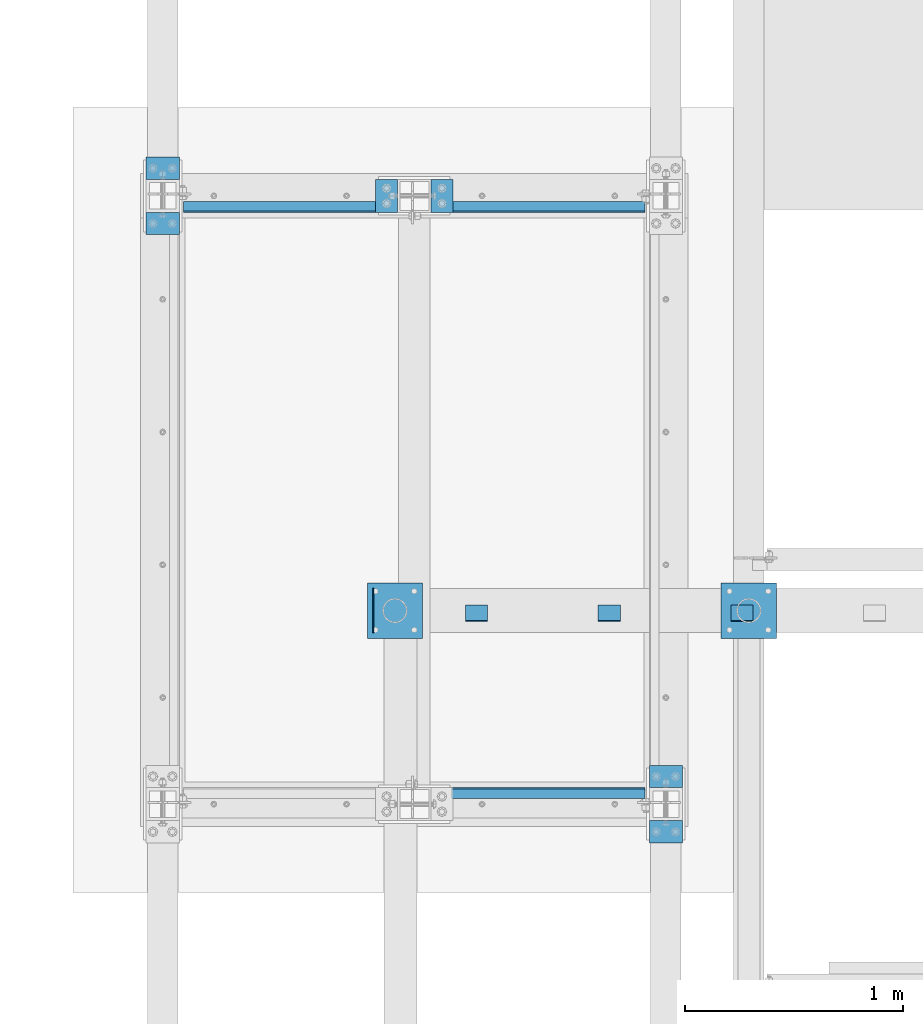
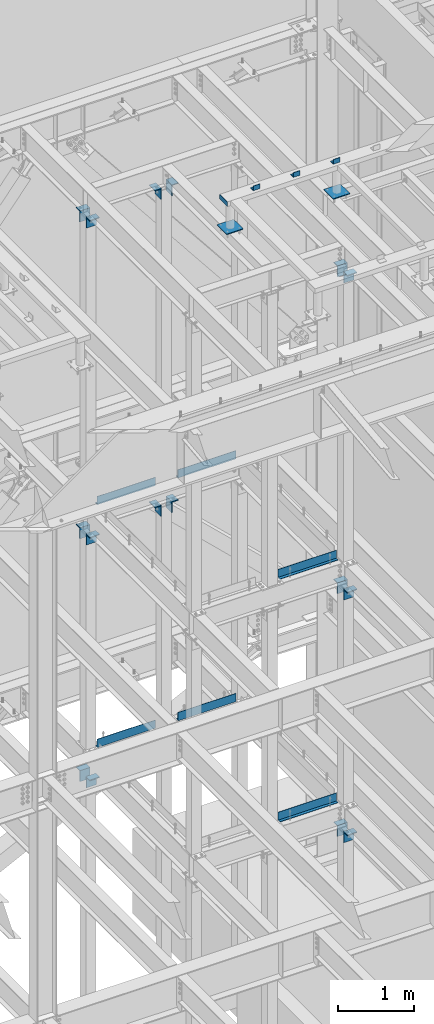
# One storey, part 892 of 1179: 28 beams, 13 elements without a shape of their own.
"""IFC2X3 building model written with IfcOpenShell, lengths in millimetres."""

from ifc_helpers import new_model, si_unit, frame, origin_with_axes, place, context, subcontext, project, spatial, faceted_brep, material, type_object, element, aggregate, save


model = new_model("IFC2X3")

# Units and contexts
model_context = context("Model", 3, precision=1e-05, world=origin_with_axes())
body_context = subcontext(model_context, "Body", "Model", "MODEL_VIEW")
ifc_project = project(units=[si_unit("LENGTHUNIT", "METRE", prefix="MILLI"), si_unit("AREAUNIT", "SQUARE_METRE"), si_unit("VOLUMEUNIT", "CUBIC_METRE"), si_unit("MASSUNIT", "GRAM", prefix="KILO"), si_unit("TIMEUNIT", "SECOND"), si_unit("PLANEANGLEUNIT", "RADIAN"), si_unit("SOLIDANGLEUNIT", "STERADIAN"), si_unit("THERMODYNAMICTEMPERATUREUNIT", "DEGREE_CELSIUS"), si_unit("LUMINOUSINTENSITYUNIT", "LUMEN")], contexts=[model_context])

# Site, building, storey
site_placement = place(None, origin_with_axes())
site = spatial("IfcSite", under=ifc_project, at=site_placement, CompositionType="ELEMENT")
building_placement = place(site_placement, origin_with_axes())
building = spatial("IfcBuilding", under=site, at=building_placement, Name="Undefined", CompositionType="ELEMENT")
storey_placement = place(building_placement, origin_with_axes())
storey = spatial("IfcBuildingStorey", under=building, at=storey_placement, Name="Undefined", CompositionType="ELEMENT", Elevation=0.0)

# Assembly, beams
assembly_1_placement = place(storey_placement, origin_with_axes())
assembly_1 = element("IfcElementAssembly", 1, at=assembly_1_placement, inside=storey, Name="FRAME", AssemblyPlace="NOTDEFINED", PredefinedType="RIGID_FRAME")
ifc_material = material(Name="STEEL/A36")
beam_type_1 = type_object("IfcBeamType", Name="L3X3X1/4", PredefinedType="NOTDEFINED")
beam_1_placement = place(assembly_1_placement, frame((14484.35, 37515.8, 13798.55), z_axis=(0.0, 1.0, 0.0), x_axis=(1.0, 0.0, 0.0)))
beam_1 = element("IfcBeam", 2, at=beam_1_placement, type_object=beam_type_1, material=ifc_material, Name="ANGLE", ObjectType="L3X3X1/4", context=body_context, shape_type="Brep", body=[
    faceted_brep([(0.0, 38.0999999999985, -38.0999999999999), (0.0, 38.0999999999985, 38.0999999999999), (101.600000000035, 38.0999999999985, 38.099999999994), (101.599999999962, 38.0999999999985, -38.1000000000058), (0.0, 31.75, 38.1000000000004), (101.600000000035, 31.75, 38.099999999994), (0.0, 31.75, -31.75), (101.599999999969, 31.75, -31.7500000000064), (0.0, -38.0999999999985, -31.75), (101.599999999969, -38.0999999999985, -31.7500000000064), (0.0, -38.0999999999985, -38.0999999999999), (101.599999999962, -38.0999999999985, -38.1000000000058)], [[[0, 1, 2, 3]], [[1, 4, 5, 2]], [[4, 6, 7, 5]], [[6, 8, 9, 7]], [[8, 10, 11, 9]], [[10, 0, 3, 11]], [[5, 7, 9, 11, 3, 2]], [[10, 8, 6, 4, 1, 0]]]),
])
beam_2_placement = place(assembly_1_placement, frame((13874.75, 37515.8, 13798.55), z_axis=(0.0, 1.0, 0.0), x_axis=(1.0, 0.0, 0.0)))
beam_2 = element("IfcBeam", 3, at=beam_2_placement, type_object=beam_type_1, material=ifc_material, Name="ANGLE", ObjectType="L3X3X1/4", context=body_context, shape_type="Brep", body=[
    faceted_brep([(0.0, 38.0999999999985, -38.0999999999999), (0.0, 38.0999999999985, 38.0999999999999), (101.600000000035, 38.0999999999985, 38.099999999994), (101.599999999962, 38.0999999999985, -38.1000000000058), (0.0, 31.75, 38.1000000000004), (101.600000000035, 31.75, 38.099999999994), (0.0, 31.75, -31.75), (101.599999999969, 31.75, -31.7500000000064), (0.0, -38.0999999999985, -31.75), (101.599999999969, -38.0999999999985, -31.7500000000064), (0.0, -38.0999999999985, -38.0999999999999), (101.599999999962, -38.0999999999985, -38.1000000000058)], [[[0, 1, 2, 3]], [[1, 4, 5, 2]], [[4, 6, 7, 5]], [[6, 8, 9, 7]], [[8, 10, 11, 9]], [[10, 0, 3, 11]], [[5, 7, 9, 11, 3, 2]], [[10, 8, 6, 4, 1, 0]]]),
])
beam_3_placement = place(assembly_1_placement, frame((13265.15, 37515.8, 13798.55), z_axis=(0.0, 1.0, 0.0), x_axis=(1.0, 0.0, 0.0)))
beam_3 = element("IfcBeam", 4, at=beam_3_placement, type_object=beam_type_1, material=ifc_material, Name="ANGLE", ObjectType="L3X3X1/4", context=body_context, shape_type="Brep", body=[
    faceted_brep([(0.0, 38.0999999999985, -38.0999999999999), (0.0, 38.0999999999985, 38.0999999999999), (101.600000000035, 38.0999999999985, 38.099999999994), (101.599999999962, 38.0999999999985, -38.1000000000058), (0.0, 31.75, 38.1000000000004), (101.600000000035, 31.75, 38.099999999994), (0.0, 31.75, -31.75), (101.599999999969, 31.75, -31.7500000000064), (0.0, -38.0999999999985, -31.75), (101.599999999969, -38.0999999999985, -31.7500000000064), (0.0, -38.0999999999985, -38.0999999999999), (101.599999999962, -38.0999999999985, -38.1000000000058)], [[[0, 1, 2, 3]], [[1, 4, 5, 2]], [[4, 6, 7, 5]], [[6, 8, 9, 7]], [[8, 10, 11, 9]], [[10, 0, 3, 11]], [[5, 7, 9, 11, 3, 2]], [[10, 8, 6, 4, 1, 0]]]),
])
beam_type_2 = type_object("IfcBeamType", PredefinedType="NOTDEFINED")
beam_4_placement = place(assembly_1_placement, frame((12842.081, 37630.1, 13722.35), z_axis=(0.0, 0.0, -1.0), x_axis=(0.0, -1.0, 0.0)))
beam_4 = element("IfcBeam", 5, at=beam_4_placement, type_object=beam_type_2, material=ifc_material, Name="PLATE", context=body_context, shape_type="Brep", body=[
    faceted_brep([(0.0, 2.38149999999951, -38.0999999999985), (0.0, 2.38149999999951, 38.0999999999985), (203.199999999997, 2.38150000000314, 38.1000000000004), (203.199999999997, 2.38150000000314, -38.1000000000004), (0.0, -2.38149999999951, 38.0999999999985), (203.199999999997, -2.38150000000314, 38.1000000000004), (0.0, -2.38149999999951, -38.0999999999985), (203.199999999997, -2.38150000000314, -38.1000000000004)], [[[0, 1, 2, 3]], [[1, 4, 5, 2]], [[4, 6, 7, 5]], [[6, 0, 3, 7]], [[5, 7, 3, 2]], [[6, 4, 1, 0]]]),
])

# Assembly, beam
assembly_2_placement = place(storey_placement, origin_with_axes())
assembly_2 = element("IfcElementAssembly", 6, at=assembly_2_placement, inside=storey, Name="BEAM", AssemblyPlace="NOTDEFINED", PredefinedType="RIGID_FRAME")
beam_type_3 = type_object("IfcBeamType", PredefinedType="NOTDEFINED")
beam_5_placement = place(assembly_2_placement, frame((13646.1498786982, 36712.5249652951, 8147.05000610352), z_axis=(1.0, 0.0, 0.0), x_axis=(0.0, 0.0, -1.0)))
beam_5 = element("IfcBeam", 7, at=beam_5_placement, type_object=beam_type_3, material=ifc_material, Name="BENT_PLATE", context=body_context, shape_type="Brep", body=[
    faceted_brep([(0.0, -3.17500000000291, -444.5), (0.0, -3.17500000000291, 444.5), (0.0, 3.17500000000291, 444.5), (0.0, 3.17500000000291, -444.5), (133.350006103513, 3.17500000000291, 444.5), (133.350006103513, 3.17500000000291, -444.5), (127.000006103513, -3.17500000000291, -444.5), (127.000006103513, -3.17500000000291, 444.5), (133.350006103513, -47.6249984741225, 444.5), (133.350006103513, -47.6249984741225, -444.5), (127.000006103513, -47.6249984741225, 444.5), (127.000006103513, -47.6249984741225, -444.5)], [[[0, 1, 2, 3]], [[3, 2, 4, 5]], [[1, 0, 6, 7]], [[5, 4, 8, 9]], [[4, 2, 1, 7, 10, 8]], [[7, 6, 11, 10]], [[6, 0, 3, 5, 9, 11]], [[10, 11, 9, 8]]]),
])
aggregate(assembly_2, [beam_5])

# Assembly, beams
assembly_3_placement = place(storey_placement, origin_with_axes())
assembly_3 = element("IfcElementAssembly", 8, at=assembly_3_placement, inside=storey, Name="BEAM", AssemblyPlace="NOTDEFINED", PredefinedType="RIGID_FRAME")
beam_6_placement = place(assembly_3_placement, frame((13646.15, 39360.4749984741, 8147.05000610352), z_axis=(1.0, 0.0, 0.0), x_axis=(0.0, 0.0, -1.0)))
beam_6 = element("IfcBeam", 9, at=beam_6_placement, type_object=beam_type_3, material=ifc_material, Name="BENT_PLATE", context=body_context, shape_type="Brep", body=[
    faceted_brep([(0.0, -3.17500000000291, -444.5), (0.0, -3.17500000000291, 444.5), (0.0, 3.17500000000291, 444.5), (0.0, 3.17500000000291, -444.5), (127.000006103513, 3.17500000000291, 444.5), (127.000006103513, 3.17500000000291, -444.5), (133.350006103513, -3.17500000000291, -444.5), (133.350006103513, -3.17500000000291, 444.5), (127.000006103513, 47.6250015258702, 444.5), (127.000006103513, 47.6250015258702, -444.5), (133.350006103513, 47.6250015258702, 444.5), (133.350006103513, 47.6250015258702, -444.5)], [[[0, 1, 2, 3]], [[3, 2, 4, 5]], [[1, 0, 6, 7]], [[5, 4, 8, 9]], [[4, 2, 1, 7, 10, 8]], [[7, 6, 11, 10]], [[6, 0, 3, 5, 9, 11]], [[10, 11, 9, 8]]]),
])
beam_7_placement = place(assembly_3_placement, frame((12414.2500030518, 39360.4749984741, 8147.05000610352), z_axis=(1.0, 0.0, 0.0), x_axis=(0.0, 0.0, -1.0)))
beam_7 = element("IfcBeam", 10, at=beam_7_placement, type_object=beam_type_3, material=ifc_material, Name="BENT_PLATE", context=body_context, shape_type="Brep", body=[
    faceted_brep([(0.0, -3.17500000000291, -444.5), (0.0, -3.17500000000291, 444.5), (0.0, 3.17500000000291, 444.5), (0.0, 3.17500000000291, -444.5), (127.000006103513, 3.17500000000291, 444.5), (127.000006103513, 3.17500000000291, -444.5), (133.350006103513, -3.17500000000291, -444.5), (133.350006103513, -3.17500000000291, 444.5), (127.000006103513, 47.6250015258702, 444.5), (127.000006103513, 47.6250015258702, -444.5), (133.350006103513, 47.6250015258702, 444.5), (133.350006103513, 47.6250015258702, -444.5)], [[[0, 1, 2, 3]], [[3, 2, 4, 5]], [[1, 0, 6, 7]], [[5, 4, 8, 9]], [[4, 2, 1, 7, 10, 8]], [[7, 6, 11, 10]], [[6, 0, 3, 5, 9, 11]], [[10, 11, 9, 8]]]),
])
aggregate(assembly_3, [beam_6, beam_7])

# Assembly, beam
assembly_4_placement = place(storey_placement, origin_with_axes())
assembly_4 = element("IfcElementAssembly", 11, at=assembly_4_placement, inside=storey, Name="BEAM", AssemblyPlace="NOTDEFINED", PredefinedType="RIGID_FRAME")
beam_8_placement = place(assembly_4_placement, frame((13646.15, 36712.5249984741, 4235.45000610352), z_axis=(1.0, 0.0, 0.0), x_axis=(0.0, 0.0, -1.0)))
beam_8 = element("IfcBeam", 12, at=beam_8_placement, type_object=beam_type_3, material=ifc_material, Name="BENT_PLATE", context=body_context, shape_type="Brep", body=[
    faceted_brep([(0.0, -3.17500000000291, -444.5), (0.0, -3.17500000000291, 444.5), (0.0, 3.17500000000291, 444.5), (0.0, 3.17500000000291, -444.5), (133.350006103513, 3.17500000000291, 444.5), (133.350006103513, 3.17500000000291, -444.5), (127.000006103513, -3.17500000000291, -444.5), (127.000006103513, -3.17500000000291, 444.5), (133.350006103513, -47.6249984741225, 444.5), (133.350006103513, -47.6249984741225, -444.5), (127.000006103513, -47.6249984741225, 444.5), (127.000006103513, -47.6249984741225, -444.5)], [[[0, 1, 2, 3]], [[3, 2, 4, 5]], [[1, 0, 6, 7]], [[5, 4, 8, 9]], [[4, 2, 1, 7, 10, 8]], [[7, 6, 11, 10]], [[6, 0, 3, 5, 9, 11]], [[10, 11, 9, 8]]]),
])
aggregate(assembly_4, [beam_8])

# Assembly, beams
assembly_5_placement = place(storey_placement, origin_with_axes())
assembly_5 = element("IfcElementAssembly", 13, at=assembly_5_placement, inside=storey, Name="BEAM", AssemblyPlace="NOTDEFINED", PredefinedType="RIGID_FRAME")
beam_9_placement = place(assembly_5_placement, frame((13646.15, 39360.4749984741, 4235.45000610352), z_axis=(1.0, 0.0, 0.0), x_axis=(0.0, 0.0, -1.0)))
beam_9 = element("IfcBeam", 14, at=beam_9_placement, type_object=beam_type_3, material=ifc_material, Name="BENT_PLATE", context=body_context, shape_type="Brep", body=[
    faceted_brep([(0.0, -3.17500000000291, -444.5), (0.0, -3.17500000000291, 444.5), (0.0, 3.17500000000291, 444.5), (0.0, 3.17500000000291, -444.5), (127.000006103513, 3.17500000000291, 444.5), (127.000006103513, 3.17500000000291, -444.5), (133.350006103513, -3.17500000000291, -444.5), (133.350006103513, -3.17500000000291, 444.5), (127.000006103513, 47.6250015258702, 444.5), (127.000006103513, 47.6250015258702, -444.5), (133.350006103513, 47.6250015258702, 444.5), (133.350006103513, 47.6250015258702, -444.5)], [[[0, 1, 2, 3]], [[3, 2, 4, 5]], [[1, 0, 6, 7]], [[5, 4, 8, 9]], [[4, 2, 1, 7, 10, 8]], [[7, 6, 11, 10]], [[6, 0, 3, 5, 9, 11]], [[10, 11, 9, 8]]]),
])
beam_10_placement = place(assembly_5_placement, frame((12414.2500030518, 39360.4749984741, 4235.45000610352), z_axis=(1.0, 0.0, 0.0), x_axis=(0.0, 0.0, -1.0)))
beam_10 = element("IfcBeam", 15, at=beam_10_placement, type_object=beam_type_3, material=ifc_material, Name="BENT_PLATE", context=body_context, shape_type="Brep", body=[
    faceted_brep([(0.0, -3.17500000000291, -444.5), (0.0, -3.17500000000291, 444.5), (0.0, 3.17500000000291, 444.5), (0.0, 3.17500000000291, -444.5), (127.000006103513, 3.17500000000291, 444.5), (127.000006103513, 3.17500000000291, -444.5), (133.350006103513, -3.17500000000291, -444.5), (133.350006103513, -3.17500000000291, 444.5), (127.000006103513, 47.6250015258702, 444.5), (127.000006103513, 47.6250015258702, -444.5), (133.350006103513, 47.6250015258702, 444.5), (133.350006103513, 47.6250015258702, -444.5)], [[[0, 1, 2, 3]], [[3, 2, 4, 5]], [[1, 0, 6, 7]], [[5, 4, 8, 9]], [[4, 2, 1, 7, 10, 8]], [[7, 6, 11, 10]], [[6, 0, 3, 5, 9, 11]], [[10, 11, 9, 8]]]),
])
aggregate(assembly_5, [beam_9, beam_10])

assembly_6_placement = place(storey_placement, origin_with_axes())
assembly_6 = element("IfcElementAssembly", 16, at=assembly_6_placement, inside=storey, Name="COLUMN", AssemblyPlace="NOTDEFINED", PredefinedType="RIGID_FRAME")
beam_type_4 = type_object("IfcBeamType", PredefinedType="NOTDEFINED")
beam_11_placement = place(assembly_6_placement, frame((12852.4000014634, 39433.5000000217, 12763.5), z_axis=(0.0, 1.0, 0.0), x_axis=(1.0, 0.0, 0.0)))
beam_11 = element("IfcBeam", 17, at=beam_11_placement, type_object=beam_type_4, material=ifc_material, Name="BENT_PLATE", context=body_context, shape_type="Brep", body=[
    faceted_brep([(7.27595761418343e-12, -6.35000000000036, -76.1999999999971), (0.0, -6.35000000000036, 76.2000000000044), (0.0, 6.35000000000036, 76.2000000000044), (-7.27595761418343e-12, 6.35000000000036, -76.1999999999971), (88.8999984741222, 6.34999999999991, 76.2000000000007), (88.8999984741222, 6.34999999999991, -76.2000000000007), (101.599998474123, -6.34999999999991, -76.2000000000007), (101.599998474123, -6.34999999999991, 76.2000000000007), (88.8999984741222, 171.450003051757, 76.2000000000007), (88.8999984741222, 171.450003051757, -76.2000000000007), (101.599998474123, 171.450003051757, 76.2000000000007), (101.599998474123, 171.450003051757, -76.2000000000007)], [[[0, 1, 2, 3]], [[3, 2, 4, 5]], [[1, 0, 6, 7]], [[5, 4, 8, 9]], [[4, 2, 1, 7, 10, 8]], [[7, 6, 11, 10]], [[6, 0, 3, 5, 9, 11]], [[10, 11, 9, 8]]]),
])
beam_12_placement = place(assembly_6_placement, frame((13207.9999984116, 39433.500000021, 12763.5), z_axis=(0.0, 1.0, 0.0), x_axis=(-1.0, 0.0, 0.0)))
beam_12 = element("IfcBeam", 18, at=beam_12_placement, type_object=beam_type_4, material=ifc_material, Name="BENT_PLATE", context=body_context, shape_type="Brep", body=[
    faceted_brep([(7.27595761418343e-12, -6.35000000000036, -76.1999999999971), (0.0, -6.35000000000036, 76.2000000000044), (0.0, 6.35000000000036, 76.2000000000044), (-7.27595761418343e-12, 6.35000000000036, -76.1999999999971), (101.599998474123, 6.34999999999991, 76.2000000000007), (101.599998474123, 6.34999999999991, -76.2000000000007), (88.8999984741222, -6.34999999999991, -76.2000000000007), (88.8999984741222, -6.34999999999991, 76.2000000000007), (101.599998474123, -171.450003051757, 76.2000000000007), (101.599998474123, -171.450003051757, -76.2000000000007), (88.8999984741222, -171.450003051757, 76.2000000000007), (88.8999984741222, -171.450003051757, -76.2000000000007)], [[[0, 1, 2, 3]], [[3, 2, 4, 5]], [[1, 0, 6, 7]], [[5, 4, 8, 9]], [[4, 2, 1, 7, 10, 8]], [[7, 6, 11, 10]], [[6, 0, 3, 5, 9, 11]], [[10, 11, 9, 8]]]),
])
aggregate(assembly_6, [beam_11, beam_12])

assembly_7_placement = place(storey_placement, origin_with_axes())
assembly_7 = element("IfcElementAssembly", 19, at=assembly_7_placement, inside=storey, Name="COLUMN", AssemblyPlace="NOTDEFINED", PredefinedType="RIGID_FRAME")
beam_13_placement = place(assembly_7_placement, frame((14185.9, 36817.2999984741, 12709.525), z_axis=(1.0, 0.0, 0.0), x_axis=(0.0, -1.0, 0.0)))
beam_13 = element("IfcBeam", 20, at=beam_13_placement, type_object=beam_type_4, material=ifc_material, Name="BENT_PLATE", context=body_context, shape_type="Brep", body=[
    faceted_brep([(7.27595761418343e-12, -6.35000000000036, -76.1999999999971), (0.0, -6.35000000000036, 76.2000000000044), (0.0, 6.35000000000036, 76.2000000000044), (-7.27595761418343e-12, 6.35000000000036, -76.1999999999971), (88.8999984741222, 6.34999999999991, 76.2000000000007), (88.8999984741222, 6.34999999999991, -76.2000000000007), (101.599998474123, -6.34999999999991, -76.2000000000007), (101.599998474123, -6.34999999999991, 76.2000000000007), (88.8999984741222, 171.450003051757, 76.2000000000007), (88.8999984741222, 171.450003051757, -76.2000000000007), (101.599998474123, 171.450003051757, 76.2000000000007), (101.599998474123, 171.450003051757, -76.2000000000007)], [[[0, 1, 2, 3]], [[3, 2, 4, 5]], [[1, 0, 6, 7]], [[5, 4, 8, 9]], [[4, 2, 1, 7, 10, 8]], [[7, 6, 11, 10]], [[6, 0, 3, 5, 9, 11]], [[10, 11, 9, 8]]]),
])
beam_14_placement = place(assembly_7_placement, frame((14185.8999991706, 36461.7000015259, 12709.525), z_axis=(1.0, 0.0, 0.0), x_axis=(0.0, 1.0, 0.0)))
beam_14 = element("IfcBeam", 21, at=beam_14_placement, type_object=beam_type_4, material=ifc_material, Name="BENT_PLATE", context=body_context, shape_type="Brep", body=[
    faceted_brep([(7.27595761418343e-12, -6.35000000000036, -76.1999999999971), (0.0, -6.35000000000036, 76.2000000000044), (0.0, 6.35000000000036, 76.2000000000044), (-7.27595761418343e-12, 6.35000000000036, -76.1999999999971), (101.599998474123, 6.34999999999991, 76.2000000000007), (101.599998474123, 6.34999999999991, -76.2000000000007), (88.8999984741222, -6.34999999999991, -76.2000000000007), (88.8999984741222, -6.34999999999991, 76.2000000000007), (101.599998474123, -171.450003051757, 76.2000000000007), (101.599998474123, -171.450003051757, -76.2000000000007), (88.8999984741222, -171.450003051757, 76.2000000000007), (88.8999984741222, -171.450003051757, -76.2000000000007)], [[[0, 1, 2, 3]], [[3, 2, 4, 5]], [[1, 0, 6, 7]], [[5, 4, 8, 9]], [[4, 2, 1, 7, 10, 8]], [[7, 6, 11, 10]], [[6, 0, 3, 5, 9, 11]], [[10, 11, 9, 8]]]),
])
aggregate(assembly_7, [beam_13, beam_14])

assembly_8_placement = place(storey_placement, origin_with_axes())
assembly_8 = element("IfcElementAssembly", 22, at=assembly_8_placement, inside=storey, Name="COLUMN", AssemblyPlace="NOTDEFINED", PredefinedType="RIGID_FRAME")
beam_15_placement = place(assembly_8_placement, frame((11874.5, 39611.2999984741, 12709.525), z_axis=(1.0, 0.0, 0.0), x_axis=(0.0, -1.0, 0.0)))
beam_15 = element("IfcBeam", 23, at=beam_15_placement, type_object=beam_type_4, material=ifc_material, Name="BENT_PLATE", context=body_context, shape_type="Brep", body=[
    faceted_brep([(7.27595761418343e-12, -6.35000000000036, -76.1999999999971), (0.0, -6.35000000000036, 76.2000000000044), (0.0, 6.35000000000036, 76.2000000000044), (-7.27595761418343e-12, 6.35000000000036, -76.1999999999971), (88.8999984741222, 6.34999999999991, 76.2000000000007), (88.8999984741222, 6.34999999999991, -76.2000000000007), (101.599998474123, -6.34999999999991, -76.2000000000007), (101.599998474123, -6.34999999999991, 76.2000000000007), (88.8999984741222, 171.450003051757, 76.2000000000007), (88.8999984741222, 171.450003051757, -76.2000000000007), (101.599998474123, 171.450003051757, 76.2000000000007), (101.599998474123, 171.450003051757, -76.2000000000007)], [[[0, 1, 2, 3]], [[3, 2, 4, 5]], [[1, 0, 6, 7]], [[5, 4, 8, 9]], [[4, 2, 1, 7, 10, 8]], [[7, 6, 11, 10]], [[6, 0, 3, 5, 9, 11]], [[10, 11, 9, 8]]]),
])
beam_16_placement = place(assembly_8_placement, frame((11874.4999991706, 39255.7000015259, 12709.525), z_axis=(1.0, 0.0, 0.0), x_axis=(0.0, 1.0, 0.0)))
beam_16 = element("IfcBeam", 24, at=beam_16_placement, type_object=beam_type_4, material=ifc_material, Name="BENT_PLATE", context=body_context, shape_type="Brep", body=[
    faceted_brep([(7.27595761418343e-12, -6.35000000000036, -76.1999999999971), (0.0, -6.35000000000036, 76.2000000000044), (0.0, 6.35000000000036, 76.2000000000044), (-7.27595761418343e-12, 6.35000000000036, -76.1999999999971), (101.599998474123, 6.34999999999991, 76.2000000000007), (101.599998474123, 6.34999999999991, -76.2000000000007), (88.8999984741222, -6.34999999999991, -76.2000000000007), (88.8999984741222, -6.34999999999991, 76.2000000000007), (101.599998474123, -171.450003051757, 76.2000000000007), (101.599998474123, -171.450003051757, -76.2000000000007), (88.8999984741222, -171.450003051757, 76.2000000000007), (88.8999984741222, -171.450003051757, -76.2000000000007)], [[[0, 1, 2, 3]], [[3, 2, 4, 5]], [[1, 0, 6, 7]], [[5, 4, 8, 9]], [[4, 2, 1, 7, 10, 8]], [[7, 6, 11, 10]], [[6, 0, 3, 5, 9, 11]], [[10, 11, 9, 8]]]),
])
aggregate(assembly_8, [beam_15, beam_16])

assembly_9_placement = place(storey_placement, origin_with_axes())
assembly_9 = element("IfcElementAssembly", 25, at=assembly_9_placement, inside=storey, Name="COLUMN", AssemblyPlace="NOTDEFINED", PredefinedType="RIGID_FRAME")
beam_17_placement = place(assembly_9_placement, frame((12852.4000015259, 39433.5, 7658.1), z_axis=(0.0, 1.0, 0.0), x_axis=(1.0, 0.0, 0.0)))
beam_17 = element("IfcBeam", 26, at=beam_17_placement, type_object=beam_type_4, material=ifc_material, Name="BENT_PLATE", context=body_context, shape_type="Brep", body=[
    faceted_brep([(7.27595761418343e-12, -6.35000000000036, -76.1999999999971), (0.0, -6.35000000000036, 76.2000000000044), (0.0, 6.35000000000036, 76.2000000000044), (-7.27595761418343e-12, 6.35000000000036, -76.1999999999971), (88.8999984741222, 6.34999999999991, 76.2000000000007), (88.8999984741222, 6.34999999999991, -76.2000000000007), (101.599998474123, -6.34999999999991, -76.2000000000007), (101.599998474123, -6.34999999999991, 76.2000000000007), (88.8999984741222, 171.450003051757, 76.2000000000007), (88.8999984741222, 171.450003051757, -76.2000000000007), (101.599998474123, 171.450003051757, 76.2000000000007), (101.599998474123, 171.450003051757, -76.2000000000007)], [[[0, 1, 2, 3]], [[3, 2, 4, 5]], [[1, 0, 6, 7]], [[5, 4, 8, 9]], [[4, 2, 1, 7, 10, 8]], [[7, 6, 11, 10]], [[6, 0, 3, 5, 9, 11]], [[10, 11, 9, 8]]]),
])
beam_18_placement = place(assembly_9_placement, frame((13207.9999984741, 39433.5, 7658.1), z_axis=(0.0, 1.0, 0.0), x_axis=(-1.0, 0.0, 0.0)))
beam_18 = element("IfcBeam", 27, at=beam_18_placement, type_object=beam_type_4, material=ifc_material, Name="BENT_PLATE", context=body_context, shape_type="Brep", body=[
    faceted_brep([(7.27595761418343e-12, -6.35000000000036, -76.1999999999971), (0.0, -6.35000000000036, 76.2000000000044), (0.0, 6.35000000000036, 76.2000000000044), (-7.27595761418343e-12, 6.35000000000036, -76.1999999999971), (101.599998474123, 6.34999999999991, 76.2000000000007), (101.599998474123, 6.34999999999991, -76.2000000000007), (88.8999984741222, -6.34999999999991, -76.2000000000007), (88.8999984741222, -6.34999999999991, 76.2000000000007), (101.599998474123, -171.450003051757, 76.2000000000007), (101.599998474123, -171.450003051757, -76.2000000000007), (88.8999984741222, -171.450003051757, 76.2000000000007), (88.8999984741222, -171.450003051757, -76.2000000000007)], [[[0, 1, 2, 3]], [[3, 2, 4, 5]], [[1, 0, 6, 7]], [[5, 4, 8, 9]], [[4, 2, 1, 7, 10, 8]], [[7, 6, 11, 10]], [[6, 0, 3, 5, 9, 11]], [[10, 11, 9, 8]]]),
])
aggregate(assembly_9, [beam_17, beam_18])

assembly_10_placement = place(storey_placement, origin_with_axes())
assembly_10 = element("IfcElementAssembly", 28, at=assembly_10_placement, inside=storey, Name="COLUMN", AssemblyPlace="NOTDEFINED", PredefinedType="RIGID_FRAME")
beam_19_placement = place(assembly_10_placement, frame((11874.4999991706, 39611.3182468785, 7604.12499649481), z_axis=(1.0, 0.0, 0.0), x_axis=(0.0, -1.0, 0.0)))
beam_19 = element("IfcBeam", 29, at=beam_19_placement, type_object=beam_type_4, material=ifc_material, Name="BENT_PLATE", context=body_context, shape_type="Brep", body=[
    faceted_brep([(7.27595761418343e-12, -6.35000000000036, -76.1999999999971), (0.0, -6.35000000000036, 76.2000000000044), (0.0, 6.35000000000036, 76.2000000000044), (-7.27595761418343e-12, 6.35000000000036, -76.1999999999971), (88.8999984741222, 6.34999999999991, 76.2000000000007), (88.8999984741222, 6.34999999999991, -76.2000000000007), (101.599998474123, -6.34999999999991, -76.2000000000007), (101.599998474123, -6.34999999999991, 76.2000000000007), (88.8999984741222, 171.450003051757, 76.2000000000007), (88.8999984741222, 171.450003051757, -76.2000000000007), (101.599998474123, 171.450003051757, 76.2000000000007), (101.599998474123, 171.450003051757, -76.2000000000007)], [[[0, 1, 2, 3]], [[3, 2, 4, 5]], [[1, 0, 6, 7]], [[5, 4, 8, 9]], [[4, 2, 1, 7, 10, 8]], [[7, 6, 11, 10]], [[6, 0, 3, 5, 9, 11]], [[10, 11, 9, 8]]]),
])
beam_20_placement = place(assembly_10_placement, frame((11874.4999991706, 39255.7000015259, 7604.12499649481), z_axis=(1.0, 0.0, 0.0), x_axis=(0.0, 1.0, 0.0)))
beam_20 = element("IfcBeam", 30, at=beam_20_placement, type_object=beam_type_4, material=ifc_material, Name="BENT_PLATE", context=body_context, shape_type="Brep", body=[
    faceted_brep([(7.27595761418343e-12, -6.35000000000036, -76.1999999999971), (0.0, -6.35000000000036, 76.2000000000044), (0.0, 6.35000000000036, 76.2000000000044), (-7.27595761418343e-12, 6.35000000000036, -76.1999999999971), (101.599998474123, 6.34999999999991, 76.2000000000007), (101.599998474123, 6.34999999999991, -76.2000000000007), (88.8999984741222, -6.34999999999991, -76.2000000000007), (88.8999984741222, -6.34999999999991, 76.2000000000007), (101.599998474123, -171.450003051757, 76.2000000000007), (101.599998474123, -171.450003051757, -76.2000000000007), (88.8999984741222, -171.450003051757, 76.2000000000007), (88.8999984741222, -171.450003051757, -76.2000000000007)], [[[0, 1, 2, 3]], [[3, 2, 4, 5]], [[1, 0, 6, 7]], [[5, 4, 8, 9]], [[4, 2, 1, 7, 10, 8]], [[7, 6, 11, 10]], [[6, 0, 3, 5, 9, 11]], [[10, 11, 9, 8]]]),
])
aggregate(assembly_10, [beam_19, beam_20])

assembly_11_placement = place(storey_placement, origin_with_axes())
assembly_11 = element("IfcElementAssembly", 31, at=assembly_11_placement, inside=storey, Name="COLUMN", AssemblyPlace="NOTDEFINED", PredefinedType="RIGID_FRAME")
beam_21_placement = place(assembly_11_placement, frame((14185.9, 36817.2999984741, 7604.12499649481), z_axis=(1.0, 0.0, 0.0), x_axis=(0.0, -1.0, 0.0)))
beam_21 = element("IfcBeam", 32, at=beam_21_placement, type_object=beam_type_4, material=ifc_material, Name="BENT_PLATE", context=body_context, shape_type="Brep", body=[
    faceted_brep([(7.27595761418343e-12, -6.35000000000036, -76.1999999999971), (0.0, -6.35000000000036, 76.2000000000044), (0.0, 6.35000000000036, 76.2000000000044), (-7.27595761418343e-12, 6.35000000000036, -76.1999999999971), (88.8999984741222, 6.34999999999991, 76.2000000000007), (88.8999984741222, 6.34999999999991, -76.2000000000007), (101.599998474123, -6.34999999999991, -76.2000000000007), (101.599998474123, -6.34999999999991, 76.2000000000007), (88.8999984741222, 171.450003051757, 76.2000000000007), (88.8999984741222, 171.450003051757, -76.2000000000007), (101.599998474123, 171.450003051757, 76.2000000000007), (101.599998474123, 171.450003051757, -76.2000000000007)], [[[0, 1, 2, 3]], [[3, 2, 4, 5]], [[1, 0, 6, 7]], [[5, 4, 8, 9]], [[4, 2, 1, 7, 10, 8]], [[7, 6, 11, 10]], [[6, 0, 3, 5, 9, 11]], [[10, 11, 9, 8]]]),
])
beam_22_placement = place(assembly_11_placement, frame((14185.9, 36461.7000015259, 7604.12499649481), z_axis=(1.0, 0.0, 0.0), x_axis=(0.0, 1.0, 0.0)))
beam_22 = element("IfcBeam", 33, at=beam_22_placement, type_object=beam_type_4, material=ifc_material, Name="BENT_PLATE", context=body_context, shape_type="Brep", body=[
    faceted_brep([(7.27595761418343e-12, -6.35000000000036, -76.1999999999971), (0.0, -6.35000000000036, 76.2000000000044), (0.0, 6.35000000000036, 76.2000000000044), (-7.27595761418343e-12, 6.35000000000036, -76.1999999999971), (101.599998474123, 6.34999999999991, 76.2000000000007), (101.599998474123, 6.34999999999991, -76.2000000000007), (88.8999984741222, -6.34999999999991, -76.2000000000007), (88.8999984741222, -6.34999999999991, 76.2000000000007), (101.599998474123, -171.450003051757, 76.2000000000007), (101.599998474123, -171.450003051757, -76.2000000000007), (88.8999984741222, -171.450003051757, 76.2000000000007), (88.8999984741222, -171.450003051757, -76.2000000000007)], [[[0, 1, 2, 3]], [[3, 2, 4, 5]], [[1, 0, 6, 7]], [[5, 4, 8, 9]], [[4, 2, 1, 7, 10, 8]], [[7, 6, 11, 10]], [[6, 0, 3, 5, 9, 11]], [[10, 11, 9, 8]]]),
])
aggregate(assembly_11, [beam_21, beam_22])

assembly_12_placement = place(storey_placement, origin_with_axes())
assembly_12 = element("IfcElementAssembly", 34, at=assembly_12_placement, inside=storey, Name="COLUMN", AssemblyPlace="NOTDEFINED", PredefinedType="RIGID_FRAME")
beam_23_placement = place(assembly_12_placement, frame((14185.9, 36817.2999984741, 3692.52499649481), z_axis=(1.0, 0.0, 0.0), x_axis=(0.0, -1.0, 0.0)))
beam_23 = element("IfcBeam", 35, at=beam_23_placement, type_object=beam_type_4, material=ifc_material, Name="BENT_PLATE", context=body_context, shape_type="Brep", body=[
    faceted_brep([(7.27595761418343e-12, -6.35000000000036, -76.1999999999971), (0.0, -6.35000000000036, 76.2000000000044), (0.0, 6.35000000000036, 76.2000000000044), (-7.27595761418343e-12, 6.35000000000036, -76.1999999999971), (88.8999984741222, 6.34999999999991, 76.2000000000007), (88.8999984741222, 6.34999999999991, -76.2000000000007), (101.599998474123, -6.34999999999991, -76.2000000000007), (101.599998474123, -6.34999999999991, 76.2000000000007), (88.8999984741222, 171.450003051757, 76.2000000000007), (88.8999984741222, 171.450003051757, -76.2000000000007), (101.599998474123, 171.450003051757, 76.2000000000007), (101.599998474123, 171.450003051757, -76.2000000000007)], [[[0, 1, 2, 3]], [[3, 2, 4, 5]], [[1, 0, 6, 7]], [[5, 4, 8, 9]], [[4, 2, 1, 7, 10, 8]], [[7, 6, 11, 10]], [[6, 0, 3, 5, 9, 11]], [[10, 11, 9, 8]]]),
])
beam_24_placement = place(assembly_12_placement, frame((14185.9, 36461.7000015259, 3692.52499649481), z_axis=(1.0, 0.0, 0.0), x_axis=(0.0, 1.0, 0.0)))
beam_24 = element("IfcBeam", 36, at=beam_24_placement, type_object=beam_type_4, material=ifc_material, Name="BENT_PLATE", context=body_context, shape_type="Brep", body=[
    faceted_brep([(7.27595761418343e-12, -6.35000000000036, -76.1999999999971), (0.0, -6.35000000000036, 76.2000000000044), (0.0, 6.35000000000036, 76.2000000000044), (-7.27595761418343e-12, 6.35000000000036, -76.1999999999971), (101.599998474123, 6.34999999999991, 76.2000000000007), (101.599998474123, 6.34999999999991, -76.2000000000007), (88.8999984741222, -6.34999999999991, -76.2000000000007), (88.8999984741222, -6.34999999999991, 76.2000000000007), (101.599998474123, -171.450003051757, 76.2000000000007), (101.599998474123, -171.450003051757, -76.2000000000007), (88.8999984741222, -171.450003051757, 76.2000000000007), (88.8999984741222, -171.450003051757, -76.2000000000007)], [[[0, 1, 2, 3]], [[3, 2, 4, 5]], [[1, 0, 6, 7]], [[5, 4, 8, 9]], [[4, 2, 1, 7, 10, 8]], [[7, 6, 11, 10]], [[6, 0, 3, 5, 9, 11]], [[10, 11, 9, 8]]]),
])
aggregate(assembly_12, [beam_23, beam_24])

assembly_13_placement = place(storey_placement, origin_with_axes())
assembly_13 = element("IfcElementAssembly", 37, at=assembly_13_placement, inside=storey, Name="COLUMN", AssemblyPlace="NOTDEFINED", PredefinedType="RIGID_FRAME")
beam_25_placement = place(assembly_13_placement, frame((11874.499998095, 39611.3182468785, 3692.52499649481), z_axis=(1.0, 0.0, 0.0), x_axis=(0.0, -1.0, 0.0)))
beam_25 = element("IfcBeam", 38, at=beam_25_placement, type_object=beam_type_4, material=ifc_material, Name="BENT_PLATE", context=body_context, shape_type="Brep", body=[
    faceted_brep([(7.27595761418343e-12, -6.35000000000036, -76.1999999999971), (0.0, -6.35000000000036, 76.2000000000044), (0.0, 6.35000000000036, 76.2000000000044), (-7.27595761418343e-12, 6.35000000000036, -76.1999999999971), (88.8999984741222, 6.34999999999991, 76.2000000000007), (88.8999984741222, 6.34999999999991, -76.2000000000007), (101.599998474123, -6.34999999999991, -76.2000000000007), (101.599998474123, -6.34999999999991, 76.2000000000007), (88.8999984741222, 171.450003051757, 76.2000000000007), (88.8999984741222, 171.450003051757, -76.2000000000007), (101.599998474123, 171.450003051757, 76.2000000000007), (101.599998474123, 171.450003051757, -76.2000000000007)], [[[0, 1, 2, 3]], [[3, 2, 4, 5]], [[1, 0, 6, 7]], [[5, 4, 8, 9]], [[4, 2, 1, 7, 10, 8]], [[7, 6, 11, 10]], [[6, 0, 3, 5, 9, 11]], [[10, 11, 9, 8]]]),
])
beam_26_placement = place(assembly_13_placement, frame((11874.5, 39255.7000015259, 3692.52499649481), z_axis=(1.0, 0.0, 0.0), x_axis=(0.0, 1.0, 0.0)))
beam_26 = element("IfcBeam", 39, at=beam_26_placement, type_object=beam_type_4, material=ifc_material, Name="BENT_PLATE", context=body_context, shape_type="Brep", body=[
    faceted_brep([(7.27595761418343e-12, -6.35000000000036, -76.1999999999971), (0.0, -6.35000000000036, 76.2000000000044), (0.0, 6.35000000000036, 76.2000000000044), (-7.27595761418343e-12, 6.35000000000036, -76.1999999999971), (101.599998474123, 6.34999999999991, 76.2000000000007), (101.599998474123, 6.34999999999991, -76.2000000000007), (88.8999984741222, -6.34999999999991, -76.2000000000007), (88.8999984741222, -6.34999999999991, 76.2000000000007), (101.599998474123, -171.450003051757, 76.2000000000007), (101.599998474123, -171.450003051757, -76.2000000000007), (88.8999984741222, -171.450003051757, 76.2000000000007), (88.8999984741222, -171.450003051757, -76.2000000000007)], [[[0, 1, 2, 3]], [[3, 2, 4, 5]], [[1, 0, 6, 7]], [[5, 4, 8, 9]], [[4, 2, 1, 7, 10, 8]], [[7, 6, 11, 10]], [[6, 0, 3, 5, 9, 11]], [[10, 11, 9, 8]]]),
])
aggregate(assembly_13, [beam_25, beam_26])

# Beam
beam_type_5 = type_object("IfcBeamType", PredefinedType="NOTDEFINED")
beam_27_placement = place(assembly_1_placement, frame((12941.3, 37401.5, 13258.8), z_axis=(1.0, 0.0, 0.0), x_axis=(0.0, 1.0, 0.0)))
beam_27 = element("IfcBeam", 40, at=beam_27_placement, type_object=beam_type_5, material=ifc_material, Name="PLATE", context=body_context, shape_type="Brep", body=[
    faceted_brep([(0.0, 6.35000000000036, -127.0), (0.0, 6.34999999999854, 127.0), (254.0, 6.35000000000036, 127.0), (254.0, 6.35000000000036, -127.0), (0.0, -6.34999999999854, 127.0), (254.0, -6.35000000000036, 127.0), (0.0, -6.35000000000036, -127.0), (254.0, -6.35000000000036, -127.0)], [[[0, 1, 2, 3]], [[1, 4, 5, 2]], [[4, 6, 7, 5]], [[6, 0, 3, 7]], [[5, 7, 3, 2]], [[6, 4, 1, 0]]]),
])

beam_28_placement = place(assembly_1_placement, frame((14566.9, 37401.5, 13258.8), z_axis=(1.0, 0.0, 0.0), x_axis=(0.0, 1.0, 0.0)))
beam_28 = element("IfcBeam", 41, at=beam_28_placement, type_object=beam_type_5, material=ifc_material, Name="PLATE", context=body_context, shape_type="Brep", body=[
    faceted_brep([(0.0, 6.35000000000036, -127.0), (0.0, 6.34999999999854, 127.0), (254.0, 6.35000000000036, 127.0), (254.0, 6.35000000000036, -127.0), (0.0, -6.34999999999854, 127.0), (254.0, -6.35000000000036, 127.0), (0.0, -6.35000000000036, -127.0), (254.0, -6.35000000000036, -127.0)], [[[0, 1, 2, 3]], [[1, 4, 5, 2]], [[4, 6, 7, 5]], [[6, 0, 3, 7]], [[5, 7, 3, 2]], [[6, 4, 1, 0]]]),
])

aggregate(assembly_1, [beam_1, beam_2, beam_3, beam_4, beam_27, beam_28])

save(model, "model.ifc")
